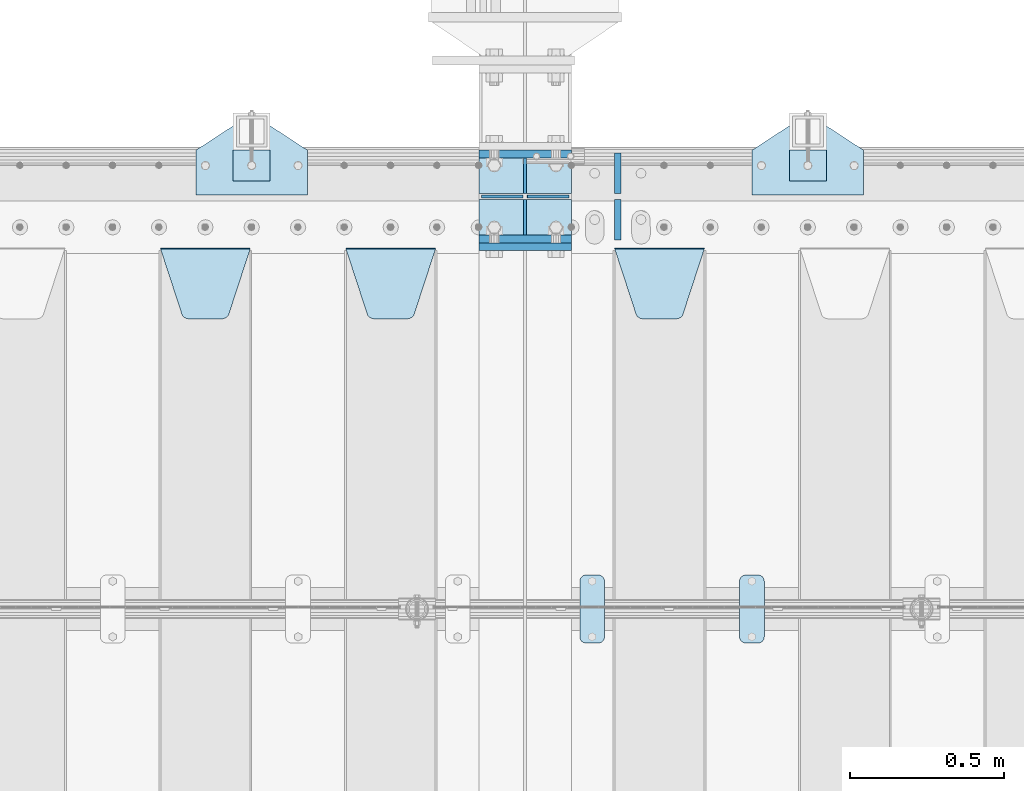
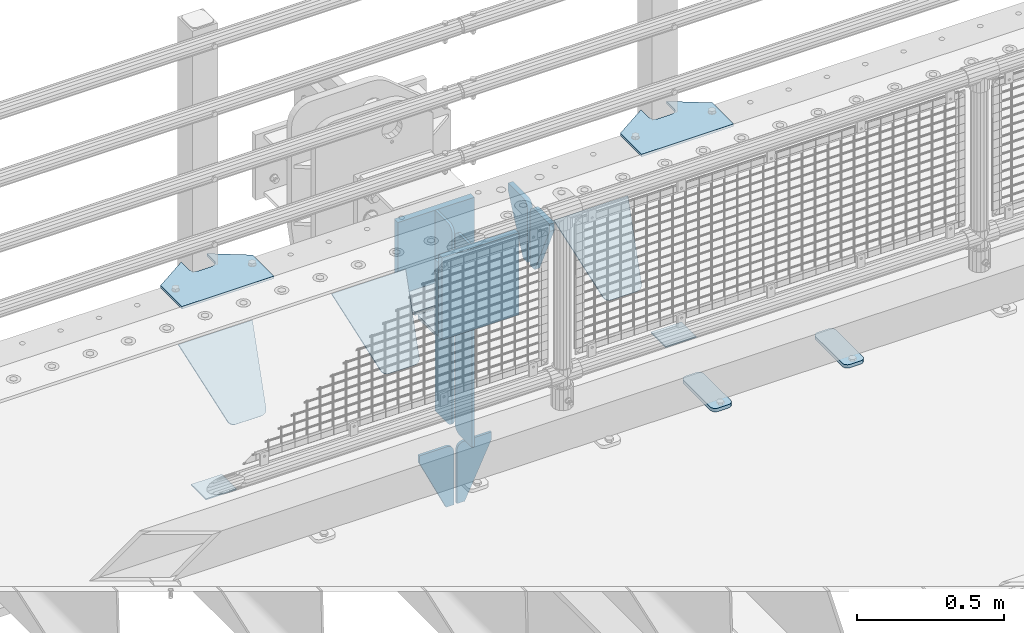
# One storey, part 238 of 270: 22 plates.
"""IFC2X3 building model written with IfcOpenShell, lengths in millimetres."""

import ifcopenshell
import ifcopenshell.guid

model = None  # the IFC model being written
_history = None  # IfcOwnerHistory: only IFC2X3 demands one
_inside = {}  # id of a spatial element -> (the spatial element, [elements in it])
_under = {}  # id of a project, library or spatial element -> (it, [spatial elements below it])
_declared = {}  # id of a project -> (the project, [libraries it declares])
_typed = {}  # id of a type object -> (the type object, [elements of that type])
_made_of = {}  # id of a material, layer set ... -> (it, [elements and type objects made of it])


def new_model(schema):
    """Start an empty IFC model of exactly this schema.

    Asked for "IFC4X3", IfcOpenShell would pick the latest addendum, in which some entities
    have other attributes; the version numbers below select the first issue.
    IFC2X3 requires an IfcOwnerHistory on every rooted entity: one is made here for all.
    """
    global model, _history
    if schema == "IFC4X3":
        model = ifcopenshell.file(schema_version=(4, 3, 0, 0))
    else:
        model = ifcopenshell.file(schema=schema)
    _inside.clear()
    _under.clear()
    _declared.clear()
    _typed.clear()
    _made_of.clear()
    _history = None
    if model.schema == "IFC2X3":
        org = make("IfcOrganization", Name="unknown")
        user = make(
            "IfcPersonAndOrganization",
            ThePerson=make("IfcPerson", FamilyName="unknown"),
            TheOrganization=org,
        )
        app = make(
            "IfcApplication",
            ApplicationDeveloper=org,
            Version="unknown",
            ApplicationFullName="unknown",
            ApplicationIdentifier="unknown",
        )
        _history = make(
            "IfcOwnerHistory",
            OwningUser=user,
            OwningApplication=app,
            ChangeAction="ADDED",
            CreationDate=0,
        )
    return model


def make(cls, **values):
    """One entity of the class cls with the attributes given. An attribute that is None is left unset."""
    return model.create_entity(
        cls, **{name: value for name, value in values.items() if value is not None}
    )


def rooted(cls, **values):
    """An entity with a GlobalId (a new one), such as an element, a storey or a relation."""
    return make(cls, GlobalId=ifcopenshell.guid.new(), OwnerHistory=_history, **values)


def si_unit(unit_type, name, prefix=None):
    """IfcSIUnit, for example si_unit("LENGTHUNIT", "METRE", prefix="MILLI")."""
    return make("IfcSIUnit", UnitType=unit_type, Prefix=prefix, Name=name)


def assignment(units):
    """IfcUnitAssignment: the units of a project."""
    return None if units is None else make("IfcUnitAssignment", Units=units)


def point(xyz):
    """IfcCartesianPoint."""
    return None if xyz is None else make("IfcCartesianPoint", Coordinates=xyz)


def direction(xyz):
    """IfcDirection."""
    return None if xyz is None else make("IfcDirection", DirectionRatios=xyz)


def frame(location, z_axis=None, x_axis=None):
    """IfcAxis2Placement3D, a coordinate frame: its origin and axes. An axis left out is left unset."""
    return make(
        "IfcAxis2Placement3D",
        Location=point(location),
        Axis=direction(z_axis),
        RefDirection=direction(x_axis),
    )


def origin_with_axes():
    """The frame at (0, 0, 0) with the z axis (0, 0, 1) and the x axis (1, 0, 0) written out."""
    return frame((0.0, 0.0, 0.0), z_axis=(0.0, 0.0, 1.0), x_axis=(1.0, 0.0, 0.0))


def place(relative_to, where):
    """IfcLocalPlacement: puts the frame where relative to a parent placement (None: the world)."""
    return make(
        "IfcLocalPlacement", PlacementRelTo=relative_to, RelativePlacement=where
    )


def context(
    kind, dimensions, precision=None, world=None, true_north=None, identifier=None
):
    """IfcGeometricRepresentationContext, for example the 3D "Model" context."""
    return make(
        "IfcGeometricRepresentationContext",
        ContextIdentifier=identifier,
        ContextType=kind,
        CoordinateSpaceDimension=dimensions,
        Precision=precision,
        WorldCoordinateSystem=world,
        TrueNorth=true_north,
    )


def subcontext(parent, identifier, kind, view, scale=None):
    """IfcGeometricRepresentationSubContext, for example "Body" below "Model"."""
    return make(
        "IfcGeometricRepresentationSubContext",
        ContextIdentifier=identifier,
        ContextType=kind,
        ParentContext=parent,
        TargetScale=scale,
        TargetView=view,
    )


def project(units=None, contexts=None):
    """IfcProject with its units and contexts."""
    return rooted(
        "IfcProject",
        Name="project",
        RepresentationContexts=contexts,
        UnitsInContext=assignment(units),
    )


def spatial(cls, under=None, at=None, **own):
    """A site, building, storey or space (cls), placed at a placement, below another one or the project."""
    s = rooted(cls, ObjectPlacement=at, **own)
    if under is not None:
        _under.setdefault(under.id(), (under, []))[1].append(s)
    return s


def faces_of(points, faces, orient=None, outer=None):
    """IfcFace entities. A face is a list of loops; a loop is a list of indices into points, from 0.

    orient and outer hold one flag for each loop. By default every Orientation is true, the
    first loop of a face is its IfcFaceOuterBound and the others are IfcFaceBound.
    """
    made = []
    for i, loops in enumerate(faces):
        bounds = []
        for j, loop in enumerate(loops):
            is_outer = j == 0 if outer is None else outer[i][j]
            bounds.append(
                make(
                    "IfcFaceOuterBound" if is_outer else "IfcFaceBound",
                    Bound=make("IfcPolyLoop", Polygon=[points[k] for k in loop]),
                    Orientation=True if orient is None else orient[i][j],
                )
            )
        made.append(make("IfcFace", Bounds=bounds))
    return made


def faceted_brep(points, faces, orient=None, outer=None, voids=None):
    """IfcFacetedBrep: a solid bounded by flat faces; with voids (closed shells), ...WithVoids."""
    shared = [point(p) for p in points]
    hull = make("IfcClosedShell", CfsFaces=faces_of(shared, faces, orient, outer))
    if voids is None:
        return make("IfcFacetedBrep", Outer=hull)
    return make(
        "IfcFacetedBrepWithVoids",
        Outer=hull,
        Voids=[
            make(cls, CfsFaces=faces_of(shared, fs, o, b)) for cls, fs, o, b in voids
        ],
    )


def shape(context_of_items, identifier, shape_type, items):
    """IfcShapeRepresentation: the items that make up one representation, for example the "Body"."""
    return make(
        "IfcShapeRepresentation",
        ContextOfItems=context_of_items,
        RepresentationIdentifier=identifier,
        RepresentationType=shape_type,
        Items=items,
    )


def material(Name=None, Category=None):
    """IfcMaterial."""
    return make("IfcMaterial", Name=Name, Category=Category)


def made_of(thing, what):
    """Note that an element or type object is made of a material, layer set ...; save() writes the relation."""
    if what is not None:
        _made_of.setdefault(what.id(), (what, []))[1].append(thing)
    return thing


def type_object(cls, material=None, **own):
    """A type object (cls), such as IfcWallType, which elements share."""
    return made_of(rooted(cls, **own), material)


def element(
    cls,
    number,
    at=None,
    inside=None,
    cuts=None,
    type_object=None,
    material=None,
    context=None,
    identifier="Body",
    shape_type=None,
    held_by="IfcProductDefinitionShape",
    body=None,
    shapes=None,
    **own,
):
    """One element of the class cls, such as IfcWall. Its Tag is "e" and its number.

    at: its placement. inside: the storey or other place that contains it. cuts: it is an
    opening in that element (IfcRelVoidsElement). A single representation is given by context,
    identifier, shape_type and body (its items); several are given by shapes. held_by: the class
    of the entity that holds the representations. save() writes the other relations.
    """
    e = rooted(cls, Tag="e%d" % number, ObjectPlacement=at, **own)
    if body is not None:
        shapes = [shape(context, identifier, shape_type, body)]
    if shapes is not None:
        e.Representation = make(held_by, Representations=shapes)
    if inside is not None:
        _inside.setdefault(inside.id(), (inside, []))[1].append(e)
    if cuts is not None:
        rooted(
            "IfcRelVoidsElement", RelatingBuildingElement=cuts, RelatedOpeningElement=e
        )
    if type_object is not None:
        _typed.setdefault(type_object.id(), (type_object, []))[1].append(e)
    return made_of(e, material)


def aggregate(whole, parts):
    """IfcRelAggregates: a whole, such as a stair, and the parts it consists of."""
    return rooted("IfcRelAggregates", RelatingObject=whole, RelatedObjects=parts)


def save(model, path):
    """Write the relations noted so far, then the file.

    IfcRelAggregates (storeys below a building ...), IfcRelContainedInSpatialStructure (elements
    in a storey), IfcRelDefinesByType, IfcRelAssociatesMaterial and IfcRelDeclares: one each for
    every whole, place, type object, material and project.
    """
    for whole, parts in _under.values():
        aggregate(whole, parts)
    for where, things in _inside.values():
        rooted(
            "IfcRelContainedInSpatialStructure",
            RelatedElements=things,
            RelatingStructure=where,
        )
    for kind, things in _typed.values():
        rooted("IfcRelDefinesByType", RelatedObjects=things, RelatingType=kind)
    for what, things in _made_of.values():
        rooted("IfcRelAssociatesMaterial", RelatedObjects=things, RelatingMaterial=what)
    for by, libraries in _declared.values():
        rooted("IfcRelDeclares", RelatingContext=by, RelatedDefinitions=libraries)
    model.write(path)


model = new_model("IFC2X3")

# Units and contexts
model_context = context("Model", 3, precision=1e-05, world=origin_with_axes())
body_context = subcontext(model_context, "Body", "Model", "MODEL_VIEW")
ifc_project = project(units=[si_unit("LENGTHUNIT", "METRE", prefix="MILLI"), si_unit("AREAUNIT", "SQUARE_METRE"), si_unit("VOLUMEUNIT", "CUBIC_METRE"), si_unit("MASSUNIT", "GRAM", prefix="KILO"), si_unit("TIMEUNIT", "SECOND"), si_unit("PLANEANGLEUNIT", "RADIAN"), si_unit("SOLIDANGLEUNIT", "STERADIAN"), si_unit("THERMODYNAMICTEMPERATUREUNIT", "DEGREE_CELSIUS"), si_unit("LUMINOUSINTENSITYUNIT", "LUMEN")], contexts=[model_context])

# Site, building, storey
site_placement = place(None, origin_with_axes())
site = spatial("IfcSite", under=ifc_project, at=site_placement, CompositionType="ELEMENT")
building_placement = place(site_placement, origin_with_axes())
building = spatial("IfcBuilding", under=site, at=building_placement, Name="Standard", CompositionType="ELEMENT")
storey_placement = place(building_placement, origin_with_axes())
storey = spatial("IfcBuildingStorey", under=building, at=storey_placement, Name="Undefined", CompositionType="ELEMENT", Elevation=0.0)

# Plates
ifc_material_1 = material(Name="STEEL/S355N")
plate_type_1 = type_object("IfcPlateType", PredefinedType="NOTDEFINED")
plate_1_placement = place(storey_placement, frame((13885.0, -15162.5, -340.000000000044), z_axis=(0.0, 0.0, 1.0), x_axis=(1.0, 0.0, 0.0)))
element("IfcPlate", 1, at=plate_1_placement, inside=storey, type_object=plate_type_1, material=ifc_material_1, context=body_context, shape_type="Brep", body=[
    faceted_brep([(0.0, -12.5, 0.0), (9.27684595808387e-10, -12.5, 340.0), (9.27684595808387e-10, 12.5, 340.0), (0.0, 12.5, 0.0), (300.0, -12.5, 340.0), (300.0, 12.5, 340.0), (300.0, -12.5, 0.0), (300.0, 12.5, 0.0)], [[[0, 1, 2, 3]], [[1, 4, 5, 2]], [[4, 6, 7, 5]], [[6, 0, 3, 7]], [[5, 7, 3, 2]], [[6, 4, 1, 0]]]),
])
for number, where, z_axis, x_axis in (
    (2, (13885.0, -14862.5, -340.0), (0.0, 0.0, 1.0), (1.0, 0.0, 0.0)),
    (3, (13885.0, -15137.5, -340.0), (0.0, 0.0, 1.0), (1.0, 0.0, 0.0)),
):
    element("IfcPlate", number, at=place(storey_placement, frame(where, z_axis=z_axis, x_axis=x_axis)), inside=storey, type_object=plate_type_1, material=ifc_material_1, context=body_context, shape_type="Brep", body=[
        faceted_brep([(0.0, -12.5, 0.0), (0.0, -12.5, 305.0), (0.0, 12.5, 305.0), (0.0, 12.5, 0.0), (300.0, -12.5, 305.0), (300.0, 12.5, 305.0), (300.0, -12.5, 0.0), (300.0, 12.5, 0.0)], [[[0, 1, 2, 3]], [[1, 4, 5, 2]], [[4, 6, 7, 5]], [[6, 0, 3, 7]], [[5, 7, 3, 2]], [[6, 4, 1, 0]]]),
    ])
plate_type_2 = type_object("IfcPlateType", PredefinedType="NOTDEFINED")
for number, where, z_axis, x_axis in (
    (4, (13885.0, -15009.25, -343.0), (0.0, -1.0, 0.0), (1.0, 0.0, 0.0)),
    (5, (13885.0, -14990.75, -343.0), (0.0, 1.0, 0.0), (1.0, 0.0, 0.0)),
):
    element("IfcPlate", number, at=place(storey_placement, frame(where, z_axis=z_axis, x_axis=x_axis)), inside=storey, type_object=plate_type_2, material=ifc_material_1, context=body_context, shape_type="Brep", body=[
        faceted_brep([(0.0, -7.0, 0.0), (0.0, -7.0, 115.75), (0.0, 7.0, 115.75), (0.0, 7.0, 0.0), (300.0, -7.0, 115.75), (300.0, 7.0, 115.75), (300.0, -7.0, 0.0), (300.0, 7.0, 0.0)], [[[0, 1, 2, 3]], [[1, 4, 5, 2]], [[4, 6, 7, 5]], [[6, 0, 3, 7]], [[5, 7, 3, 2]], [[6, 4, 1, 0]]]),
    ])
plate_type_3 = type_object("IfcPlateType", PredefinedType="NOTDEFINED")
plate_2_placement = place(storey_placement, frame((14035.0, -14990.75, -35.0), z_axis=(0.0, 0.0, -1.0), x_axis=(0.0, 1.0, 0.0)))
element("IfcPlate", 6, at=plate_2_placement, inside=storey, type_object=plate_type_3, material=ifc_material_1, context=body_context, shape_type="Brep", body=[
    faceted_brep([(0.0, -5.0, 30.0), (0.0, -5.0, 301.0), (0.0, 5.0, 301.0), (0.0, 5.0, 30.0), (115.75, -5.0, 301.0), (115.75, 5.0, 301.0), (115.75, -5.0, 0.0), (115.75, 5.0, 0.0), (30.0, -5.0, 0.0), (30.0, 5.0, 0.0), (24.7905546699913, -5.0, 0.455767409633758), (24.7905546699913, 5.0, 0.455767409633758), (19.7393957002314, -5.0, 1.80922137642275), (19.7393957002314, 5.0, 1.80922137642275), (15.0, -5.0, 4.01923788646684), (15.0, 5.0, 4.01923788646684), (10.7163717094045, -5.0, 7.01866670643066), (10.7163717094045, 5.0, 7.01866670643066), (7.01866670642994, -5.0, 10.7163717094038), (7.01866670642994, 5.0, 10.7163717094038), (4.01923788646673, -5.0, 15.0), (4.01923788646673, 5.0, 15.0), (1.80922137642119, -5.0, 19.7393957002299), (1.80922137642119, 5.0, 19.7393957002299), (0.455767409632244, -5.0, 24.7905546699921), (0.455767409632244, 5.0, 24.7905546699921)], [[[0, 1, 2, 3]], [[1, 4, 5, 2]], [[4, 6, 7, 5]], [[6, 8, 9, 7]], [[8, 10, 11, 9]], [[10, 12, 13, 11]], [[12, 14, 15, 13]], [[14, 16, 17, 15]], [[16, 18, 19, 17]], [[18, 20, 21, 19]], [[20, 22, 23, 21]], [[22, 24, 25, 23]], [[24, 0, 3, 25]], [[5, 7, 9, 11, 13, 15, 17, 19, 21, 23, 25, 3, 2]], [[24, 22, 20, 18, 16, 14, 12, 10, 8, 6, 4, 1, 0]]]),
])
for number, where, z_axis, x_axis in (
    (7, (14035.0, -15009.25, -350.0), (0.0, 0.0, -1.0), (0.0, -1.0, 0.0)),
    (8, (14035.0, -14990.75, -350.0), (0.0, 0.0, -1.0), (0.0, 1.0, 0.0)),
):
    element("IfcPlate", number, at=place(storey_placement, frame(where, z_axis=z_axis, x_axis=x_axis)), inside=storey, type_object=plate_type_3, material=ifc_material_1, context=body_context, shape_type="Brep", body=[
        faceted_brep([(0.0, -5.0, 0.0), (0.0, -5.0, 485.0), (0.0, 5.0, 485.0), (0.0, 5.0, 0.0), (0.455767409634063, -5.0, 490.209445330008), (0.455767409634063, 5.0, 490.209445330008), (1.80922137642301, -5.0, 495.26060429977), (1.80922137642301, 5.0, 495.26060429977), (4.01923788646673, -5.0, 500.0), (4.01923788646673, 5.0, 500.0), (7.01866670642994, -5.0, 504.283628290596), (7.01866670642994, 5.0, 504.283628290596), (10.7163717094045, -5.0, 507.981333293569), (10.7163717094045, 5.0, 507.981333293569), (15.0, -5.0, 510.980762113533), (15.0, 5.0, 510.980762113533), (19.7393957002296, -5.0, 513.190778623577), (19.7393957002296, 5.0, 513.190778623577), (24.7905546699913, -5.0, 514.544232590366), (24.7905546699913, 5.0, 514.544232590366), (30.0, -5.0, 515.0), (30.0, 5.0, 515.0), (115.75, -5.0, 515.0), (115.75, 5.0, 515.0), (115.75, -5.0, 0.0), (115.75, 5.0, 0.0)], [[[0, 1, 2, 3]], [[1, 4, 5, 2]], [[4, 6, 7, 5]], [[6, 8, 9, 7]], [[8, 10, 11, 9]], [[10, 12, 13, 11]], [[12, 14, 15, 13]], [[14, 16, 17, 15]], [[16, 18, 19, 17]], [[18, 20, 21, 19]], [[20, 22, 23, 21]], [[22, 24, 25, 23]], [[24, 0, 3, 25]], [[5, 7, 9, 11, 13, 15, 17, 19, 21, 23, 25, 3, 2]], [[24, 22, 20, 18, 16, 14, 12, 10, 8, 6, 4, 1, 0]]]),
    ])
plate_3_placement = place(storey_placement, frame((14035.0, -15009.25, -35.0), z_axis=(0.0, 0.0, -1.0), x_axis=(0.0, -1.0, 0.0)))
element("IfcPlate", 9, at=plate_3_placement, inside=storey, type_object=plate_type_3, material=ifc_material_1, context=body_context, shape_type="Brep", body=[
    faceted_brep([(0.0, -5.0, 30.0), (0.0, -5.0, 301.0), (0.0, 5.0, 301.0), (0.0, 5.0, 30.0), (115.75, -5.0, 301.0), (115.75, 5.0, 301.0), (115.75, -5.0, 0.0), (115.75, 5.0, 0.0), (30.0, -5.0, 0.0), (30.0, 5.0, 0.0), (24.7905546699913, -5.0, 0.455767409633758), (24.7905546699913, 5.0, 0.455767409633758), (19.7393957002314, -5.0, 1.80922137642275), (19.7393957002314, 5.0, 1.80922137642275), (15.0, -5.0, 4.01923788646684), (15.0, 5.0, 4.01923788646684), (10.7163717094045, -5.0, 7.01866670643066), (10.7163717094045, 5.0, 7.01866670643066), (7.01866670642994, -5.0, 10.7163717094038), (7.01866670642994, 5.0, 10.7163717094038), (4.01923788646673, -5.0, 15.0), (4.01923788646673, 5.0, 15.0), (1.80922137642119, -5.0, 19.7393957002299), (1.80922137642119, 5.0, 19.7393957002299), (0.455767409632244, -5.0, 24.7905546699921), (0.455767409632244, 5.0, 24.7905546699921)], [[[0, 1, 2, 3]], [[1, 4, 5, 2]], [[4, 6, 7, 5]], [[6, 8, 9, 7]], [[8, 10, 11, 9]], [[10, 12, 13, 11]], [[12, 14, 15, 13]], [[14, 16, 17, 15]], [[16, 18, 19, 17]], [[18, 20, 21, 19]], [[20, 22, 23, 21]], [[22, 24, 25, 23]], [[24, 0, 3, 25]], [[5, 7, 9, 11, 13, 15, 17, 19, 21, 23, 25, 3, 2]], [[24, 22, 20, 18, 16, 14, 12, 10, 8, 6, 4, 1, 0]]]),
])
ifc_material_2 = material(Name="STEEL/S355J2")
plate_type_4 = type_object("IfcPlateType", PredefinedType="NOTDEFINED")
plate_4_placement = place(storey_placement, frame((14770.0, -14995.0, 5.00000000004911), z_axis=(0.0, 1.0, 0.0), x_axis=(1.0, 0.0, 0.0)))
element("IfcPlate", 10, at=plate_4_placement, inside=storey, type_object=plate_type_4, material=ifc_material_2, context=body_context, shape_type="Brep", body=[
    faceted_brep([(0.0, -5.0, 0.0), (2.31396552408114e-06, -5.0, 145.0), (2.31396552408114e-06, 5.0, 145.0), (0.0, 5.0, 0.0), (130.0, -5.0, 230.0), (130.0, 5.0, 230.0), (130.0, -5.0, 180.0), (130.0, 5.0, 180.0), (130.48036798992, -5.0, 175.122741949597), (130.48036798992, 5.0, 175.122741949597), (131.903011687216, -5.0, 170.432914190873), (131.903011687216, 5.0, 170.432914190873), (134.213259692435, -5.0, 166.11074417451), (134.213259692435, 5.0, 166.11074417451), (137.322330470335, -5.0, 162.322330470337), (137.322330470335, 5.0, 162.322330470337), (141.110744174512, -5.0, 159.213259692437), (141.110744174512, 5.0, 159.213259692437), (145.432914190871, -5.0, 156.903011687218), (145.432914190871, 5.0, 156.903011687218), (150.122741949595, -5.0, 155.48036798992), (150.122741949595, 5.0, 155.48036798992), (155.0, -5.0, 155.0), (155.0, 5.0, 155.0), (205.0, -5.0, 155.0), (205.0, 5.0, 155.0), (209.877258050405, -5.0, 155.48036798992), (209.877258050405, 5.0, 155.48036798992), (214.567085809129, -5.0, 156.903011687218), (214.567085809129, 5.0, 156.903011687218), (218.889255825488, -5.0, 159.213259692437), (218.889255825488, 5.0, 159.213259692437), (222.677669529665, -5.0, 162.322330470337), (222.677669529665, 5.0, 162.322330470337), (225.786740307565, -5.0, 166.11074417451), (225.786740307565, 5.0, 166.11074417451), (228.096988312784, -5.0, 170.432914190873), (228.096988312784, 5.0, 170.432914190873), (229.51963201008, -5.0, 175.122741949597), (229.51963201008, 5.0, 175.122741949597), (230.0, -5.0, 180.0), (230.0, 5.0, 180.0), (230.0, -5.0, 230.0), (230.0, 5.0, 230.0), (360.0, -5.0, 145.0), (360.0, 5.0, 145.0), (360.0, -5.0, -7.27595761418343e-12), (360.0, 5.0, -7.27595761418343e-12)], [[[0, 1, 2, 3]], [[1, 4, 5, 2]], [[4, 6, 7, 5]], [[6, 8, 9, 7]], [[8, 10, 11, 9]], [[10, 12, 13, 11]], [[12, 14, 15, 13]], [[14, 16, 17, 15]], [[16, 18, 19, 17]], [[18, 20, 21, 19]], [[20, 22, 23, 21]], [[22, 24, 25, 23]], [[24, 26, 27, 25]], [[26, 28, 29, 27]], [[28, 30, 31, 29]], [[30, 32, 33, 31]], [[32, 34, 35, 33]], [[34, 36, 37, 35]], [[36, 38, 39, 37]], [[38, 40, 41, 39]], [[40, 42, 43, 41]], [[42, 44, 45, 43]], [[44, 46, 47, 45]], [[46, 0, 3, 47]], [[5, 7, 9, 11, 13, 15, 17, 19, 21, 23, 25, 27, 29, 31, 33, 35, 37, 39, 41, 43, 45, 47, 3, 2]], [[46, 44, 42, 40, 38, 36, 34, 32, 30, 28, 26, 24, 22, 20, 18, 16, 14, 12, 10, 8, 6, 4, 1, 0]]]),
])
plate_5_placement = place(storey_placement, frame((12970.0, -14995.0, 5.00000000004911), z_axis=(0.0, 1.0, 0.0), x_axis=(1.0, 0.0, 0.0)))
element("IfcPlate", 11, at=plate_5_placement, inside=storey, type_object=plate_type_4, material=ifc_material_2, context=body_context, shape_type="Brep", body=[
    faceted_brep([(0.0, -5.0, 0.0), (2.31396552408114e-06, -5.0, 145.0), (2.31396552408114e-06, 5.0, 145.0), (0.0, 5.0, 0.0), (130.0, -5.0, 230.0), (130.0, 5.0, 230.0), (130.0, -5.0, 180.0), (130.0, 5.0, 180.0), (130.48036798992, -5.0, 175.122741949597), (130.48036798992, 5.0, 175.122741949597), (131.903011687216, -5.0, 170.432914190873), (131.903011687216, 5.0, 170.432914190873), (134.213259692435, -5.0, 166.11074417451), (134.213259692435, 5.0, 166.11074417451), (137.322330470335, -5.0, 162.322330470337), (137.322330470335, 5.0, 162.322330470337), (141.110744174512, -5.0, 159.213259692437), (141.110744174512, 5.0, 159.213259692437), (145.432914190871, -5.0, 156.903011687218), (145.432914190871, 5.0, 156.903011687218), (150.122741949595, -5.0, 155.48036798992), (150.122741949595, 5.0, 155.48036798992), (155.0, -5.0, 155.0), (155.0, 5.0, 155.0), (205.0, -5.0, 155.0), (205.0, 5.0, 155.0), (209.877258050405, -5.0, 155.48036798992), (209.877258050405, 5.0, 155.48036798992), (214.567085809129, -5.0, 156.903011687218), (214.567085809129, 5.0, 156.903011687218), (218.889255825488, -5.0, 159.213259692437), (218.889255825488, 5.0, 159.213259692437), (222.677669529665, -5.0, 162.322330470337), (222.677669529665, 5.0, 162.322330470337), (225.786740307565, -5.0, 166.11074417451), (225.786740307565, 5.0, 166.11074417451), (228.096988312784, -5.0, 170.432914190873), (228.096988312784, 5.0, 170.432914190873), (229.51963201008, -5.0, 175.122741949597), (229.51963201008, 5.0, 175.122741949597), (230.0, -5.0, 180.0), (230.0, 5.0, 180.0), (230.0, -5.0, 230.0), (230.0, 5.0, 230.0), (360.0, -5.0, 145.0), (360.0, 5.0, 145.0), (360.0, -5.0, -7.27595761418343e-12), (360.0, 5.0, -7.27595761418343e-12)], [[[0, 1, 2, 3]], [[1, 4, 5, 2]], [[4, 6, 7, 5]], [[6, 8, 9, 7]], [[8, 10, 11, 9]], [[10, 12, 13, 11]], [[12, 14, 15, 13]], [[14, 16, 17, 15]], [[16, 18, 19, 17]], [[18, 20, 21, 19]], [[20, 22, 23, 21]], [[22, 24, 25, 23]], [[24, 26, 27, 25]], [[26, 28, 29, 27]], [[28, 30, 31, 29]], [[30, 32, 33, 31]], [[32, 34, 35, 33]], [[34, 36, 37, 35]], [[36, 38, 39, 37]], [[38, 40, 41, 39]], [[40, 42, 43, 41]], [[42, 44, 45, 43]], [[44, 46, 47, 45]], [[46, 0, 3, 47]], [[5, 7, 9, 11, 13, 15, 17, 19, 21, 23, 25, 27, 29, 31, 33, 35, 37, 39, 41, 43, 45, 47, 3, 2]], [[46, 44, 42, 40, 38, 36, 34, 32, 30, 28, 26, 24, 22, 20, 18, 16, 14, 12, 10, 8, 6, 4, 1, 0]]]),
])
plate_type_5 = type_object("IfcPlateType", PredefinedType="NOTDEFINED")
for number, where, z_axis, x_axis in (
    (12, (14890.0000000001, -14949.9999999998, -857.500000000002), (0.0, 1.0, 0.0), (1.0, 0.0, 0.0)),
    (13, (13090.0000000001, -14949.9999999998, -857.500000000002), (0.0, 1.0, 0.0), (1.0, 0.0, 0.0)),
):
    element("IfcPlate", number, at=place(storey_placement, frame(where, z_axis=z_axis, x_axis=x_axis)), inside=storey, type_object=plate_type_5, material=ifc_material_2, context=body_context, shape_type="Brep", body=[
        faceted_brep([(0.0, -2.5, 0.0), (0.0, -2.5, 100.0), (0.0, 2.5, 100.0), (0.0, 2.5, 0.0), (120.0, -2.5, 100.0), (120.0, 2.5, 100.0), (120.0, -2.5, 0.0), (120.0, 2.5, 0.0)], [[[0, 1, 2, 3]], [[1, 4, 5, 2]], [[4, 6, 7, 5]], [[6, 0, 3, 7]], [[5, 7, 3, 2]], [[6, 4, 1, 0]]]),
    ])
plate_type_6 = type_object("IfcPlateType", PredefinedType="NOTDEFINED")
plate_6_placement = place(storey_placement, frame((14729.0, -16225.5, 21.0199999999977), z_axis=(1.0, 0.0, 0.0), x_axis=(0.0, -1.0, 0.0)))
element("IfcPlate", 14, at=plate_6_placement, inside=storey, type_object=plate_type_6, material=ifc_material_2, context=body_context, shape_type="Brep", body=[
    faceted_brep([(0.0, -7.0, 20.0), (0.0, -7.0, 60.0), (0.0, 7.0, 60.0), (0.0, 7.0, 20.0), (0.384294391937146, -7.0, 63.9018064403208), (0.384294391937146, 7.0, 63.9018064403208), (1.52240934977453, -7.0, 67.6536686473009), (1.52240934977453, 7.0, 67.6536686473009), (3.37060775395003, -7.0, 71.1114046603907), (3.37060775395003, 7.0, 71.1114046603907), (5.8578643762703, -7.0, 74.1421356237297), (5.8578643762703, 7.0, 74.1421356237297), (8.88859533960931, -7.0, 76.62939224605), (8.88859533960931, 7.0, 76.62939224605), (12.3463313526991, -7.0, 78.4775906502255), (12.3463313526991, 7.0, 78.4775906502255), (16.0981935596792, -7.0, 79.6157056080629), (16.0981935596792, 7.0, 79.6157056080629), (20.0, -7.0, 80.0), (20.0, 7.0, 80.0), (200.0, -7.0, 80.0), (200.0, 7.0, 80.0), (203.901806440321, -7.0, 79.6157056080629), (203.901806440321, 7.0, 79.6157056080629), (207.653668647301, -7.0, 78.4775906502255), (207.653668647301, 7.0, 78.4775906502255), (211.111404660391, -7.0, 76.62939224605), (211.111404660391, 7.0, 76.62939224605), (214.142135623733, -7.0, 74.1421356237297), (214.142135623733, 7.0, 74.1421356237297), (216.629392246054, -7.0, 71.1114046603907), (216.629392246054, 7.0, 71.1114046603907), (218.477590650225, -7.0, 67.6536686473009), (218.477590650225, 7.0, 67.6536686473009), (219.615705608063, -7.0, 63.9018064403208), (219.615705608063, 7.0, 63.9018064403208), (220.0, -7.0, 60.0), (220.0, 7.0, 60.0), (220.0, -7.0, 20.0), (220.0, 7.0, 20.0), (219.615705608063, -7.0, 16.0981935596792), (219.615705608063, 7.0, 16.0981935596792), (218.477590650225, -7.0, 12.3463313526991), (218.477590650225, 7.0, 12.3463313526991), (216.629392246054, -7.0, 8.88859533960931), (216.629392246054, 7.0, 8.88859533960931), (214.142135623733, -7.0, 5.8578643762703), (214.142135623733, 7.0, 5.8578643762703), (211.111404660391, -7.0, 3.37060775395003), (211.111404660391, 7.0, 3.37060775395003), (207.653668647301, -7.0, 1.52240934977453), (207.653668647301, 7.0, 1.52240934977453), (203.901806440321, -7.0, 0.384294391937146), (203.901806440321, 7.0, 0.384294391937146), (200.0, -7.0, 0.0), (200.0, 7.0, 0.0), (20.0, -7.0, 0.0), (20.0, 7.0, 0.0), (16.0981935596792, -7.0, 0.384294391937146), (16.0981935596792, 7.0, 0.384294391937146), (12.3463313526991, -7.0, 1.52240934977453), (12.3463313526991, 7.0, 1.52240934977453), (8.88859533960931, -7.0, 3.37060775395003), (8.88859533960931, 7.0, 3.37060775395003), (5.8578643762703, -7.0, 5.8578643762703), (5.8578643762703, 7.0, 5.8578643762703), (3.37060775395003, -7.0, 8.88859533960931), (3.37060775395003, 7.0, 8.88859533960931), (1.52240934977453, -7.0, 12.3463313526991), (1.52240934977453, 7.0, 12.3463313526991), (0.384294391937146, -7.0, 16.0981935596792), (0.384294391937146, 7.0, 16.0981935596792)], [[[0, 1, 2, 3]], [[1, 4, 5, 2]], [[4, 6, 7, 5]], [[6, 8, 9, 7]], [[8, 10, 11, 9]], [[10, 12, 13, 11]], [[12, 14, 15, 13]], [[14, 16, 17, 15]], [[16, 18, 19, 17]], [[18, 20, 21, 19]], [[20, 22, 23, 21]], [[22, 24, 25, 23]], [[24, 26, 27, 25]], [[26, 28, 29, 27]], [[28, 30, 31, 29]], [[30, 32, 33, 31]], [[32, 34, 35, 33]], [[34, 36, 37, 35]], [[36, 38, 39, 37]], [[38, 40, 41, 39]], [[40, 42, 43, 41]], [[42, 44, 45, 43]], [[44, 46, 47, 45]], [[46, 48, 49, 47]], [[48, 50, 51, 49]], [[50, 52, 53, 51]], [[52, 54, 55, 53]], [[54, 56, 57, 55]], [[56, 58, 59, 57]], [[58, 60, 61, 59]], [[60, 62, 63, 61]], [[62, 64, 65, 63]], [[64, 66, 67, 65]], [[66, 68, 69, 67]], [[68, 70, 71, 69]], [[70, 0, 3, 71]], [[5, 7, 9, 11, 13, 15, 17, 19, 21, 23, 25, 27, 29, 31, 33, 35, 37, 39, 41, 43, 45, 47, 49, 51, 53, 55, 57, 59, 61, 63, 65, 67, 69, 71, 3, 2]], [[70, 68, 66, 64, 62, 60, 58, 56, 54, 52, 50, 48, 46, 44, 42, 40, 38, 36, 34, 32, 30, 28, 26, 24, 22, 20, 18, 16, 14, 12, 10, 8, 6, 4, 1, 0]]]),
])
plate_7_placement = place(storey_placement, frame((14212.0, -16225.5, 21.0199999999977), z_axis=(1.0, 0.0, 0.0), x_axis=(0.0, -1.0, 0.0)))
element("IfcPlate", 15, at=plate_7_placement, inside=storey, type_object=plate_type_6, material=ifc_material_2, context=body_context, shape_type="Brep", body=[
    faceted_brep([(0.0, -7.0, 20.0), (0.0, -7.0, 60.0), (0.0, 7.0, 60.0), (0.0, 7.0, 20.0), (0.384294391937146, -7.0, 63.9018064403208), (0.384294391937146, 7.0, 63.9018064403208), (1.52240934977453, -7.0, 67.6536686473009), (1.52240934977453, 7.0, 67.6536686473009), (3.37060775395003, -7.0, 71.1114046603907), (3.37060775395003, 7.0, 71.1114046603907), (5.8578643762703, -7.0, 74.1421356237297), (5.8578643762703, 7.0, 74.1421356237297), (8.88859533960931, -7.0, 76.62939224605), (8.88859533960931, 7.0, 76.62939224605), (12.3463313526991, -7.0, 78.4775906502255), (12.3463313526991, 7.0, 78.4775906502255), (16.0981935596792, -7.0, 79.6157056080629), (16.0981935596792, 7.0, 79.6157056080629), (20.0, -7.0, 80.0), (20.0, 7.0, 80.0), (200.0, -7.0, 80.0), (200.0, 7.0, 80.0), (203.901806440321, -7.0, 79.6157056080629), (203.901806440321, 7.0, 79.6157056080629), (207.653668647301, -7.0, 78.4775906502255), (207.653668647301, 7.0, 78.4775906502255), (211.111404660391, -7.0, 76.62939224605), (211.111404660391, 7.0, 76.62939224605), (214.142135623733, -7.0, 74.1421356237297), (214.142135623733, 7.0, 74.1421356237297), (216.629392246054, -7.0, 71.1114046603907), (216.629392246054, 7.0, 71.1114046603907), (218.477590650225, -7.0, 67.6536686473009), (218.477590650225, 7.0, 67.6536686473009), (219.615705608063, -7.0, 63.9018064403208), (219.615705608063, 7.0, 63.9018064403208), (220.0, -7.0, 60.0), (220.0, 7.0, 60.0), (220.0, -7.0, 20.0), (220.0, 7.0, 20.0), (219.615705608063, -7.0, 16.0981935596792), (219.615705608063, 7.0, 16.0981935596792), (218.477590650225, -7.0, 12.3463313526991), (218.477590650225, 7.0, 12.3463313526991), (216.629392246054, -7.0, 8.88859533960931), (216.629392246054, 7.0, 8.88859533960931), (214.142135623733, -7.0, 5.8578643762703), (214.142135623733, 7.0, 5.8578643762703), (211.111404660391, -7.0, 3.37060775395003), (211.111404660391, 7.0, 3.37060775395003), (207.653668647301, -7.0, 1.52240934977453), (207.653668647301, 7.0, 1.52240934977453), (203.901806440321, -7.0, 0.384294391937146), (203.901806440321, 7.0, 0.384294391937146), (200.0, -7.0, 0.0), (200.0, 7.0, 0.0), (20.0, -7.0, 0.0), (20.0, 7.0, 0.0), (16.0981935596792, -7.0, 0.384294391937146), (16.0981935596792, 7.0, 0.384294391937146), (12.3463313526991, -7.0, 1.52240934977453), (12.3463313526991, 7.0, 1.52240934977453), (8.88859533960931, -7.0, 3.37060775395003), (8.88859533960931, 7.0, 3.37060775395003), (5.8578643762703, -7.0, 5.8578643762703), (5.8578643762703, 7.0, 5.8578643762703), (3.37060775395003, -7.0, 8.88859533960931), (3.37060775395003, 7.0, 8.88859533960931), (1.52240934977453, -7.0, 12.3463313526991), (1.52240934977453, 7.0, 12.3463313526991), (0.384294391937146, -7.0, 16.0981935596792), (0.384294391937146, 7.0, 16.0981935596792)], [[[0, 1, 2, 3]], [[1, 4, 5, 2]], [[4, 6, 7, 5]], [[6, 8, 9, 7]], [[8, 10, 11, 9]], [[10, 12, 13, 11]], [[12, 14, 15, 13]], [[14, 16, 17, 15]], [[16, 18, 19, 17]], [[18, 20, 21, 19]], [[20, 22, 23, 21]], [[22, 24, 25, 23]], [[24, 26, 27, 25]], [[26, 28, 29, 27]], [[28, 30, 31, 29]], [[30, 32, 33, 31]], [[32, 34, 35, 33]], [[34, 36, 37, 35]], [[36, 38, 39, 37]], [[38, 40, 41, 39]], [[40, 42, 43, 41]], [[42, 44, 45, 43]], [[44, 46, 47, 45]], [[46, 48, 49, 47]], [[48, 50, 51, 49]], [[50, 52, 53, 51]], [[52, 54, 55, 53]], [[54, 56, 57, 55]], [[56, 58, 59, 57]], [[58, 60, 61, 59]], [[60, 62, 63, 61]], [[62, 64, 65, 63]], [[64, 66, 67, 65]], [[66, 68, 69, 67]], [[68, 70, 71, 69]], [[70, 0, 3, 71]], [[5, 7, 9, 11, 13, 15, 17, 19, 21, 23, 25, 27, 29, 31, 33, 35, 37, 39, 41, 43, 45, 47, 49, 51, 53, 55, 57, 59, 61, 63, 65, 67, 69, 71, 3, 2]], [[70, 68, 66, 64, 62, 60, 58, 56, 54, 52, 50, 48, 46, 44, 42, 40, 38, 36, 34, 32, 30, 28, 26, 24, 22, 20, 18, 16, 14, 12, 10, 8, 6, 4, 1, 0]]]),
])
plate_type_7 = type_object("IfcPlateType", PredefinedType="NOTDEFINED")
for number, where, z_axis, x_axis in (
    (16, (14028.5000000029, -15000.0000000457, -925.000018238936), (0.0, 0.0, -1.0), (-1.0, 0.0, 0.0)),
    (17, (14041.500000003, -15000.0000000457, -925.000018238936), (0.0, 0.0, -1.0), (1.0, 0.0, 0.0)),
):
    element("IfcPlate", number, at=place(storey_placement, frame(where, z_axis=z_axis, x_axis=x_axis)), inside=storey, type_object=plate_type_7, material=ifc_material_1, context=body_context, shape_type="Brep", body=[
        faceted_brep([(0.0, -5.0, 27.0), (0.0, -5.0, 250.0), (0.0, 5.0, 250.0), (0.0, 5.0, 27.0), (30.0, -5.0, 250.0), (30.0, 5.0, 250.0), (135.0, -5.0, 30.0), (135.0, 5.0, 30.0), (135.0, -5.0, 0.0), (135.0, 5.0, 0.0), (27.0, -5.0, 0.0), (27.0, 5.0, 0.0), (22.3114992029932, -5.0, 0.410190668670339), (22.3114992029932, 5.0, 0.410190668670339), (17.7654561302061, -5.0, 1.62829923878053), (17.7654561302061, 5.0, 1.62829923878053), (13.5, -5.0, 3.6173140978201), (13.5, 5.0, 3.6173140978201), (9.64473453846404, -5.0, 6.31680003578754), (9.64473453846404, 5.0, 6.31680003578754), (6.31680003578731, -5.0, 9.64473453846347), (6.31680003578731, 5.0, 9.64473453846347), (3.61731409782078, -5.0, 13.5), (3.61731409782078, 5.0, 13.5), (1.62829923878053, -5.0, 17.765456130207), (1.62829923878053, 5.0, 17.765456130207), (0.410190668670111, -5.0, 22.3114992029929), (0.410190668670111, 5.0, 22.3114992029929)], [[[0, 1, 2, 3]], [[1, 4, 5, 2]], [[4, 6, 7, 5]], [[6, 8, 9, 7]], [[8, 10, 11, 9]], [[10, 12, 13, 11]], [[12, 14, 15, 13]], [[14, 16, 17, 15]], [[16, 18, 19, 17]], [[18, 20, 21, 19]], [[20, 22, 23, 21]], [[22, 24, 25, 23]], [[24, 26, 27, 25]], [[26, 0, 3, 27]], [[5, 7, 9, 11, 13, 15, 17, 19, 21, 23, 25, 27, 3, 2]], [[26, 24, 22, 20, 18, 16, 14, 12, 10, 8, 6, 4, 1, 0]]]),
    ])
plate_type_8 = type_object("IfcPlateType", PredefinedType="NOTDEFINED")
plate_8_placement = place(storey_placement, frame((14325.0, -15168.2322330441, -1.76776695296576), z_axis=(0.0, -0.707106781186548, -0.707106781186547), x_axis=(1.0, 0.0, 0.0)))
element("IfcPlate", 18, at=plate_8_placement, inside=storey, type_object=plate_type_8, material=ifc_material_1, context=body_context, shape_type="Brep", body=[
    faceted_brep([(0.0, -2.5, 0.0), (69.345504679477, -2.5, 300.171731424831), (69.345504679477, 2.5, 300.171731424831), (0.0, 2.5, 0.0), (70.9274061199576, -2.5, 304.8974424154), (70.9274061199576, 2.5, 304.8974424154), (73.3818627772307, -2.49999999999818, 309.234538108527), (73.3818627772307, 2.50000000000182, 309.234538108527), (76.6187032999551, -2.5, 313.023683126103), (76.6187032999551, 2.5, 313.023683126103), (80.5190132704993, -2.5, 316.125672595372), (80.5190132704993, 2.50000000000182, 316.125672595372), (84.9395038596849, -2.49999999999818, 318.426546230476), (84.9395038596849, 2.5, 318.426546230476), (89.7177759439219, -2.49999999999818, 319.841774983275), (89.7177759439219, 2.50000000000182, 319.841774983275), (94.678286292652, -2.5, 320.319366455078), (94.678286292652, 2.5, 320.319366455078), (195.321713707348, -2.5, 320.319366455078), (195.321713707348, 2.5, 320.319366455078), (200.282224056078, -2.49999999999818, 319.841774983275), (200.282224056078, 2.50000000000182, 319.841774983275), (205.060496140315, -2.5, 318.426546230476), (205.060496140315, 2.5, 318.426546230476), (209.480986729501, -2.5, 316.12567259537), (209.480986729501, 2.50000000000182, 316.12567259537), (213.381296700045, -2.5, 313.023683126103), (213.381296700045, 2.5, 313.023683126103), (216.618137222769, -2.49999999999818, 309.234538108525), (216.618137222769, 2.50000000000182, 309.234538108527), (219.072593880042, -2.49999999999818, 304.897442415398), (219.072593880042, 2.50000000000182, 304.897442415397), (220.654495320523, -2.5, 300.171731424831), (220.654495320523, 2.5, 300.171731424831), (290.0, -2.49999999999818, 0.0), (290.0, 2.5, 0.0)], [[[0, 1, 2, 3]], [[1, 4, 5, 2]], [[4, 6, 7, 5]], [[6, 8, 9, 7]], [[8, 10, 11, 9]], [[10, 12, 13, 11]], [[12, 14, 15, 13]], [[14, 16, 17, 15]], [[16, 18, 19, 17]], [[18, 20, 21, 19]], [[20, 22, 23, 21]], [[22, 24, 25, 23]], [[24, 26, 27, 25]], [[26, 28, 29, 27]], [[28, 30, 31, 29]], [[30, 32, 33, 31]], [[32, 34, 35, 33]], [[34, 0, 3, 35]], [[5, 7, 9, 11, 13, 15, 17, 19, 21, 23, 25, 27, 29, 31, 33, 35, 3, 2]], [[34, 32, 30, 28, 26, 24, 22, 20, 18, 16, 14, 12, 10, 8, 6, 4, 1, 0]]]),
])
plate_9_placement = place(storey_placement, frame((13455.0, -15168.2322330441, -1.76776695296576), z_axis=(0.0, -0.707106781186548, -0.707106781186547), x_axis=(1.0, 0.0, 0.0)))
element("IfcPlate", 19, at=plate_9_placement, inside=storey, type_object=plate_type_8, material=ifc_material_1, context=body_context, shape_type="Brep", body=[
    faceted_brep([(0.0, -2.5, 0.0), (69.345504679477, -2.5, 300.171731424831), (69.345504679477, 2.5, 300.171731424831), (0.0, 2.5, 0.0), (70.9274061199576, -2.5, 304.8974424154), (70.9274061199576, 2.5, 304.8974424154), (73.3818627772307, -2.49999999999818, 309.234538108527), (73.3818627772307, 2.50000000000182, 309.234538108527), (76.6187032999551, -2.5, 313.023683126103), (76.6187032999551, 2.5, 313.023683126103), (80.5190132704993, -2.5, 316.125672595372), (80.5190132704993, 2.50000000000182, 316.125672595372), (84.9395038596849, -2.49999999999818, 318.426546230476), (84.9395038596849, 2.5, 318.426546230476), (89.7177759439219, -2.49999999999818, 319.841774983275), (89.7177759439219, 2.50000000000182, 319.841774983275), (94.678286292652, -2.5, 320.319366455078), (94.678286292652, 2.5, 320.319366455078), (195.321713707348, -2.5, 320.319366455078), (195.321713707348, 2.5, 320.319366455078), (200.282224056078, -2.49999999999818, 319.841774983275), (200.282224056078, 2.50000000000182, 319.841774983275), (205.060496140315, -2.5, 318.426546230476), (205.060496140315, 2.5, 318.426546230476), (209.480986729501, -2.5, 316.12567259537), (209.480986729501, 2.50000000000182, 316.12567259537), (213.381296700045, -2.5, 313.023683126103), (213.381296700045, 2.5, 313.023683126103), (216.618137222769, -2.49999999999818, 309.234538108525), (216.618137222769, 2.50000000000182, 309.234538108527), (219.072593880042, -2.49999999999818, 304.897442415398), (219.072593880042, 2.50000000000182, 304.897442415397), (220.654495320523, -2.5, 300.171731424831), (220.654495320523, 2.5, 300.171731424831), (290.0, -2.49999999999818, 0.0), (290.0, 2.5, 0.0)], [[[0, 1, 2, 3]], [[1, 4, 5, 2]], [[4, 6, 7, 5]], [[6, 8, 9, 7]], [[8, 10, 11, 9]], [[10, 12, 13, 11]], [[12, 14, 15, 13]], [[14, 16, 17, 15]], [[16, 18, 19, 17]], [[18, 20, 21, 19]], [[20, 22, 23, 21]], [[22, 24, 25, 23]], [[24, 26, 27, 25]], [[26, 28, 29, 27]], [[28, 30, 31, 29]], [[30, 32, 33, 31]], [[32, 34, 35, 33]], [[34, 0, 3, 35]], [[5, 7, 9, 11, 13, 15, 17, 19, 21, 23, 25, 27, 29, 31, 33, 35, 3, 2]], [[34, 32, 30, 28, 26, 24, 22, 20, 18, 16, 14, 12, 10, 8, 6, 4, 1, 0]]]),
])
plate_10_placement = place(storey_placement, frame((12855.0, -15168.2322330441, -1.76776695296576), z_axis=(0.0, -0.707106781186548, -0.707106781186547), x_axis=(1.0, 0.0, 0.0)))
element("IfcPlate", 20, at=plate_10_placement, inside=storey, type_object=plate_type_8, material=ifc_material_1, context=body_context, shape_type="Brep", body=[
    faceted_brep([(0.0, -2.5, 0.0), (69.345504679477, -2.5, 300.171731424831), (69.345504679477, 2.5, 300.171731424831), (0.0, 2.5, 0.0), (70.9274061199576, -2.5, 304.8974424154), (70.9274061199576, 2.5, 304.8974424154), (73.3818627772307, -2.49999999999818, 309.234538108527), (73.3818627772307, 2.50000000000182, 309.234538108527), (76.6187032999551, -2.5, 313.023683126103), (76.6187032999551, 2.5, 313.023683126103), (80.5190132704993, -2.5, 316.125672595372), (80.5190132704993, 2.50000000000182, 316.125672595372), (84.9395038596849, -2.49999999999818, 318.426546230476), (84.9395038596849, 2.5, 318.426546230476), (89.7177759439219, -2.49999999999818, 319.841774983275), (89.7177759439219, 2.50000000000182, 319.841774983275), (94.678286292652, -2.5, 320.319366455078), (94.678286292652, 2.5, 320.319366455078), (195.321713707348, -2.5, 320.319366455078), (195.321713707348, 2.5, 320.319366455078), (200.282224056078, -2.49999999999818, 319.841774983275), (200.282224056078, 2.50000000000182, 319.841774983275), (205.060496140315, -2.5, 318.426546230476), (205.060496140315, 2.5, 318.426546230476), (209.480986729501, -2.5, 316.12567259537), (209.480986729501, 2.50000000000182, 316.12567259537), (213.381296700045, -2.5, 313.023683126103), (213.381296700045, 2.5, 313.023683126103), (216.618137222769, -2.49999999999818, 309.234538108525), (216.618137222769, 2.50000000000182, 309.234538108527), (219.072593880042, -2.49999999999818, 304.897442415398), (219.072593880042, 2.50000000000182, 304.897442415397), (220.654495320523, -2.5, 300.171731424831), (220.654495320523, 2.5, 300.171731424831), (290.0, -2.49999999999818, 0.0), (290.0, 2.5, 0.0)], [[[0, 1, 2, 3]], [[1, 4, 5, 2]], [[4, 6, 7, 5]], [[6, 8, 9, 7]], [[8, 10, 11, 9]], [[10, 12, 13, 11]], [[12, 14, 15, 13]], [[14, 16, 17, 15]], [[16, 18, 19, 17]], [[18, 20, 21, 19]], [[20, 22, 23, 21]], [[22, 24, 25, 23]], [[24, 26, 27, 25]], [[26, 28, 29, 27]], [[28, 30, 31, 29]], [[30, 32, 33, 31]], [[32, 34, 35, 33]], [[34, 0, 3, 35]], [[5, 7, 9, 11, 13, 15, 17, 19, 21, 23, 25, 27, 29, 31, 33, 35, 3, 2]], [[34, 32, 30, 28, 26, 24, 22, 20, 18, 16, 14, 12, 10, 8, 6, 4, 1, 0]]]),
])
plate_type_9 = type_object("IfcPlateType", PredefinedType="NOTDEFINED")
for number, where, z_axis, x_axis in (
    (21, (14335.0, -14858.75, -35.0), (0.0, 0.0, -1.0), (0.0, -1.0, 0.0)),
    (22, (14335.0, -15141.25, -35.0), (0.0, 0.0, -1.0), (0.0, 1.0, 0.0)),
):
    element("IfcPlate", number, at=place(storey_placement, frame(where, z_axis=z_axis, x_axis=x_axis)), inside=storey, type_object=plate_type_9, material=ifc_material_1, context=body_context, shape_type="Brep", body=[
        faceted_brep([(0.0, -10.0, 0.0), (0.0, -10.0, 30.0), (0.0, 10.0, 30.0), (0.0, 10.0, 0.0), (102.0, -10.0, 250.0), (102.0, 10.0, 250.0), (132.0, -10.0, 250.0), (132.0, 10.0, 250.0), (132.0, -10.0, 30.0), (132.0, 10.0, 30.0), (131.544232590368, -10.0, 24.790554669992), (131.544232590368, 10.0, 24.790554669992), (130.190778623579, -10.0, 19.7393957002299), (130.190778623579, 10.0, 19.7393957002299), (127.980762113533, -10.0, 15.0), (127.980762113533, 10.0, 15.0), (124.98133329357, -10.0, 10.7163717094038), (124.98133329357, 10.0, 10.7163717094038), (121.283628290596, -10.0, 7.01866670643062), (121.283628290596, 10.0, 7.01866670643062), (117.0, -10.0, 4.01923788646684), (117.0, 10.0, 4.01923788646684), (112.260604299769, -10.0, 1.80922137642278), (112.260604299769, 10.0, 1.80922137642278), (107.209445330009, -10.0, 0.455767409633722), (107.209445330009, 10.0, 0.455767409633722), (102.0, -10.0, 0.0), (102.0, 10.0, 0.0)], [[[0, 1, 2, 3]], [[1, 4, 5, 2]], [[4, 6, 7, 5]], [[6, 8, 9, 7]], [[8, 10, 11, 9]], [[10, 12, 13, 11]], [[12, 14, 15, 13]], [[14, 16, 17, 15]], [[16, 18, 19, 17]], [[18, 20, 21, 19]], [[20, 22, 23, 21]], [[22, 24, 25, 23]], [[24, 26, 27, 25]], [[26, 0, 3, 27]], [[5, 7, 9, 11, 13, 15, 17, 19, 21, 23, 25, 27, 3, 2]], [[26, 24, 22, 20, 18, 16, 14, 12, 10, 8, 6, 4, 1, 0]]]),
    ])

save(model, "model.ifc")
